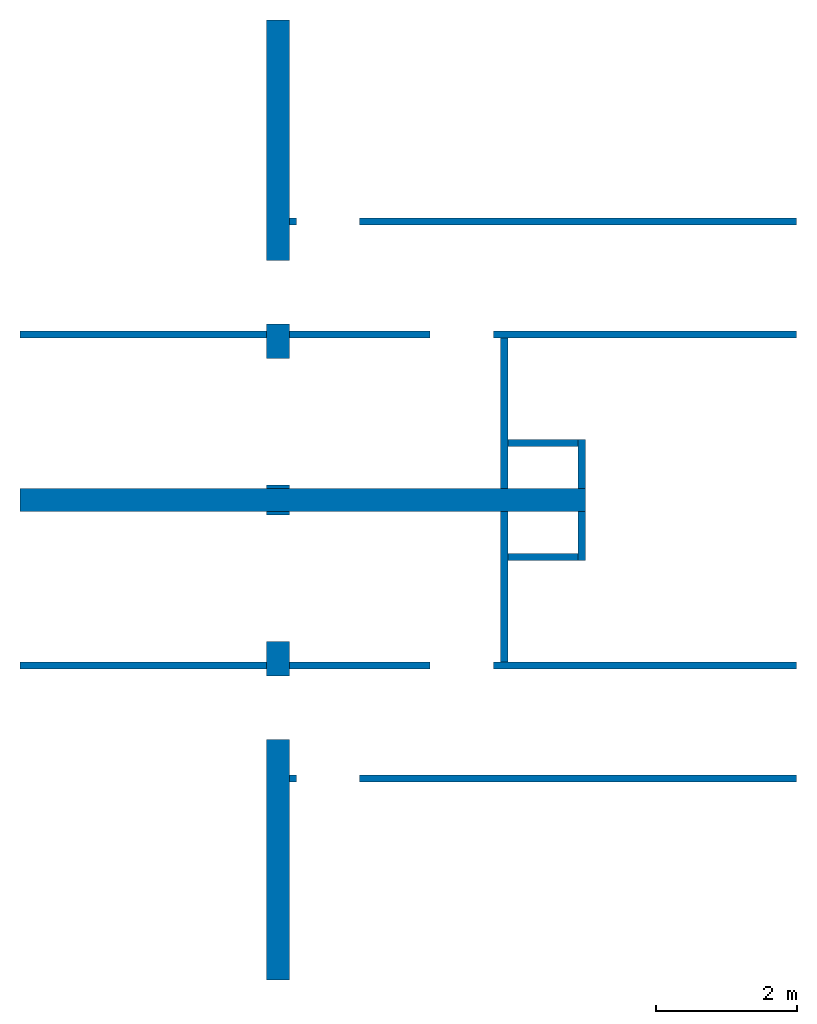
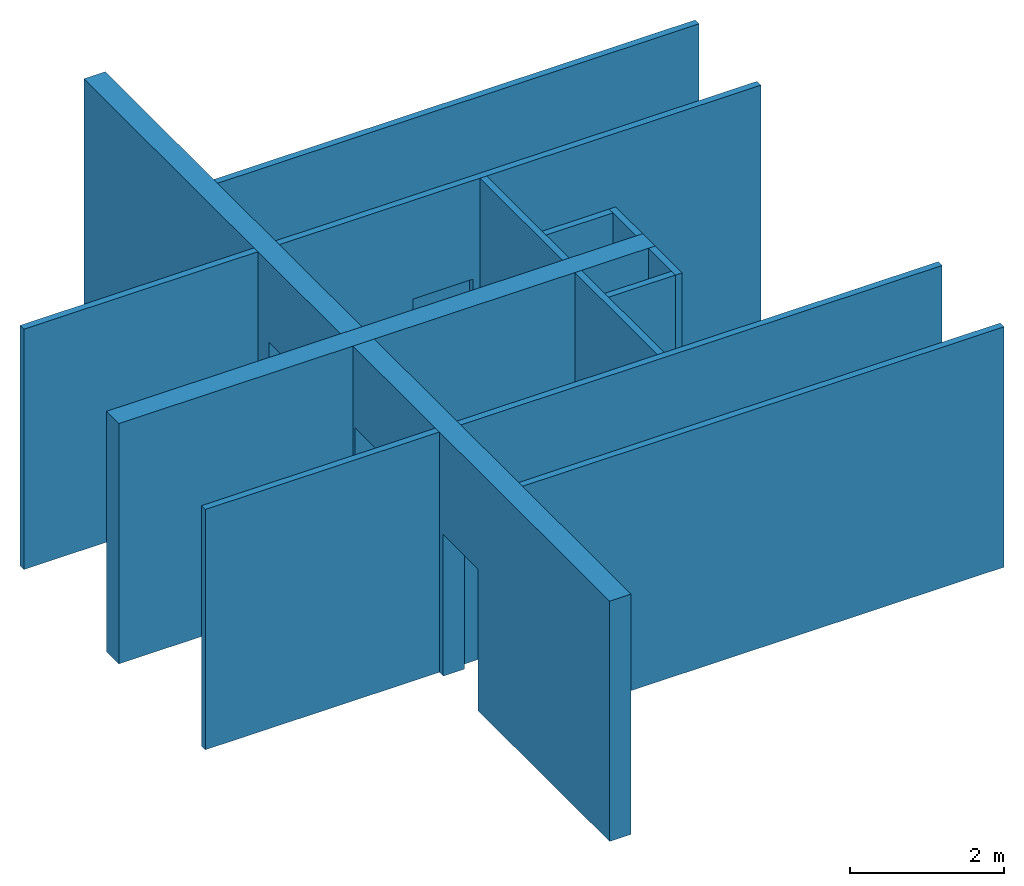
# One storey: 15 walls, 8 openings.
"""IFC2X3 building model written with IfcOpenShell, lengths in millimetres."""

from ifc_helpers import new_model, entity, si_unit, converted_unit, derived_unit, direction, frame, frame_2d, origin, origin_2d_with_axis, place, context, subcontext, project, spatial, rectangle, extrude, material, layer, layer_set, layer_usage, type_object, element, save


model = new_model("IFC2X3")

# Units and contexts
model_context = context("Model", 3, precision=0.01, world=origin(), true_north=direction((6.12303176911189e-17, 1.0)))
body_context = subcontext(model_context, "Body", "Model", "MODEL_VIEW")
ifc_project = project(units=[si_unit("LENGTHUNIT", "METRE", prefix="MILLI"), si_unit("AREAUNIT", "SQUARE_METRE"), si_unit("VOLUMEUNIT", "CUBIC_METRE"), converted_unit("PLANEANGLEUNIT", "DEGREE", entity("IfcRatioMeasure", 0.0174532925199433), si_unit("PLANEANGLEUNIT", "RADIAN"), dimensions=[0, 0, 0, 0, 0, 0, 0]), si_unit("MASSUNIT", "GRAM", prefix="KILO"), derived_unit("MASSDENSITYUNIT", [(si_unit("MASSUNIT", "GRAM", prefix="KILO"), 1), (si_unit("LENGTHUNIT", "METRE"), -3)]), si_unit("TIMEUNIT", "SECOND"), si_unit("FREQUENCYUNIT", "HERTZ"), si_unit("THERMODYNAMICTEMPERATUREUNIT", "DEGREE_CELSIUS"), derived_unit("THERMALTRANSMITTANCEUNIT", [(si_unit("MASSUNIT", "GRAM", prefix="KILO"), 1), (si_unit("THERMODYNAMICTEMPERATUREUNIT", "KELVIN"), -1), (si_unit("TIMEUNIT", "SECOND"), -3)]), derived_unit("VOLUMETRICFLOWRATEUNIT", [(si_unit("LENGTHUNIT", "METRE"), 3), (si_unit("TIMEUNIT", "SECOND"), -1)]), si_unit("ELECTRICCURRENTUNIT", "AMPERE"), si_unit("ELECTRICVOLTAGEUNIT", "VOLT"), si_unit("POWERUNIT", "WATT"), si_unit("FORCEUNIT", "NEWTON", prefix="KILO"), si_unit("ILLUMINANCEUNIT", "LUX"), si_unit("LUMINOUSFLUXUNIT", "LUMEN"), si_unit("LUMINOUSINTENSITYUNIT", "CANDELA"), derived_unit("USERDEFINED", [(si_unit("MASSUNIT", "GRAM", prefix="KILO"), -1), (si_unit("LENGTHUNIT", "METRE"), -2), (si_unit("TIMEUNIT", "SECOND"), 3), (si_unit("LUMINOUSFLUXUNIT", "LUMEN"), 1)]), derived_unit("LINEARVELOCITYUNIT", [(si_unit("LENGTHUNIT", "METRE"), 1), (si_unit("TIMEUNIT", "SECOND"), -1)]), si_unit("PRESSUREUNIT", "PASCAL"), derived_unit("USERDEFINED", [(si_unit("LENGTHUNIT", "METRE"), -2), (si_unit("MASSUNIT", "GRAM", prefix="KILO"), 1), (si_unit("TIMEUNIT", "SECOND"), -2)])], contexts=[model_context])

# Site, building, storey
site_placement = place(None, origin())
site = spatial("IfcSite", under=ifc_project, at=site_placement, CompositionType="ELEMENT")
building_placement = place(site_placement, origin())
building = spatial("IfcBuilding", under=site, at=building_placement, CompositionType="ELEMENT")
storey_placement = place(building_placement, origin())
storey = spatial("IfcBuildingStorey", under=building, at=storey_placement, Name="00 Ground level", CompositionType="ELEMENT", Elevation=0.0)

# Wall
ifc_material_1 = material(Name="03")
ifc_layer_1 = layer(ifc_material_1, 10.0)
ifc_material_2 = material()
ifc_layer_2 = layer(ifc_material_2, 300.0)
ifc_layer_3 = layer(ifc_material_1, 10.0)
ifc_layer_set_1 = layer_set([ifc_layer_1, ifc_layer_2, ifc_layer_3], Name="Basic Wall:01_fal 300 mm")
ifc_layer_usage_1 = layer_usage(ifc_layer_set_1, "AXIS2", "NEGATIVE", 160.0)
wall_type_1 = type_object("IfcWallType", Name="Basic Wall:01_fal 300 mm", PredefinedType="STANDARD", material=ifc_layer_set_1)
wall_1_placement = place(storey_placement, frame((17483.4900708518, -68831.2395851399, -140.0)))
element("IfcWallStandardCase", 1, at=wall_1_placement, inside=storey, type_object=wall_type_1, material=ifc_layer_usage_1, Name="Basic Wall:01_fal 300 mm", ObjectType="Basic Wall:01_fal 300 mm", context=body_context, shape_type="SweptSolid", body=[
    extrude(rectangle(XDim=8020.00000000003, YDim=319.999999999997, at=frame_2d((4010.00000000001, -5.96855898038484e-13), x_axis=(-1.0, 0.0))), origin(), (0.0, 0.0, 1.0), 3800.0),
])

# Wall, openings
ifc_layer_usage_2 = layer_usage(ifc_layer_set_1, "AXIS2", "NEGATIVE", 160.0)
wall_2_placement = place(storey_placement, frame((21143.4900708518, -75641.2395851399, -140.0), z_axis=(0.0, 0.0, 1.0), x_axis=(0.0, 1.0, 0.0)))
wall_2 = element("IfcWallStandardCase", 2, at=wall_2_placement, inside=storey, type_object=wall_type_1, material=ifc_layer_usage_2, Name="Basic Wall:01_fal 300 mm", ObjectType="Basic Wall:01_fal 300 mm", context=body_context, shape_type="SweptSolid", body=[
    extrude(rectangle(XDim=6650.0, YDim=319.999999999997, at=frame_2d((3325.0, 4.2632564145606e-14), x_axis=(-1.0, 0.0))), origin(), (0.0, 0.0, 1.0), 3800.0),
])
opening_1_placement = place(wall_2_placement, frame((4800.0, 160.0, 0.0)))
element("IfcOpeningElement", 3, at=opening_1_placement, cuts=wall_2, Name="Basic Wall:01_fal 300 mm", ObjectType="Opening", context=body_context, shape_type="SweptSolid", body=[
    extrude(rectangle(XDim=2540.0, YDim=1800.0, at=frame_2d((0.0, 4.32009983342141e-12), x_axis=(1.0, 0.0))), frame((900.0, -320.0, 1270.0), z_axis=(0.0, 1.0, 0.0), x_axis=(0.0, 0.0, -1.0)), (0.0, 0.0, 1.0), 319.999999999997),
])
opening_2_placement = place(wall_2_placement, frame((3410.0, 1364.0, 0.0), z_axis=(0.0, 0.0, 1.0), x_axis=(0.0, -1.0, 0.0)))
element("IfcOpeningElement", 4, at=opening_2_placement, cuts=wall_2, Name="Basic Wall:01_fal 300 mm", ObjectType="Opening", context=body_context, shape_type="SweptSolid", body=[
    extrude(rectangle(XDim=2240.0, YDim=900.000000000003, at=origin_2d_with_axis()), frame((3048.0, 450.0, 1120.0), z_axis=(-1.0, 0.0, 0.0), x_axis=(0.0, 0.0, 1.0)), (0.0, 0.0, 1.0), 3048.0),
])

ifc_layer_usage_3 = layer_usage(ifc_layer_set_1, "AXIS2", "POSITIVE", -160.0)
wall_3_placement = place(storey_placement, frame((21143.4900708518, -62021.2395851399, -140.0), z_axis=(0.0, 0.0, 1.0), x_axis=(0.0, -1.0, 0.0)))
wall_3 = element("IfcWallStandardCase", 5, at=wall_3_placement, inside=storey, type_object=wall_type_1, material=ifc_layer_usage_3, Name="Basic Wall:01_fal 300 mm", ObjectType="Basic Wall:01_fal 300 mm", context=body_context, shape_type="SweptSolid", body=[
    extrude(rectangle(XDim=6650.0, YDim=319.999999999997, at=frame_2d((3325.0, -5.82645043323282e-13), x_axis=(-1.0, 0.0))), origin(), (0.0, 0.0, 1.0), 3800.0),
])
opening_3_placement = place(wall_3_placement, frame((6600.0, -160.0, 0.0)))
element("IfcOpeningElement", 6, at=opening_3_placement, cuts=wall_3, Name="Basic Wall:01_fal 300 mm", ObjectType="Opening", context=body_context, shape_type="SweptSolid", body=[
    extrude(rectangle(XDim=2540.0, YDim=1800.0, at=frame_2d((0.0, 4.32009983342141e-12), x_axis=(1.0, 0.0))), frame((-900.0, 0.0, 1270.0), z_axis=(0.0, 1.0, 0.0), x_axis=(0.0, 0.0, -1.0)), (0.0, 0.0, 1.0), 319.999999999997),
])
opening_4_placement = place(wall_3_placement, frame((4310.0, -1364.0, 0.0), z_axis=(0.0, 0.0, 1.0), x_axis=(0.0, 1.0, 0.0)))
element("IfcOpeningElement", 7, at=opening_4_placement, cuts=wall_3, Name="Basic Wall:01_fal 300 mm", ObjectType="Opening", context=body_context, shape_type="SweptSolid", body=[
    extrude(rectangle(XDim=2240.0, YDim=900.000000000003, at=origin_2d_with_axis()), frame((0.0, 450.0, 1120.0), z_axis=(1.0, 0.0, 0.0), x_axis=(0.0, 0.0, 1.0)), (0.0, 0.0, 1.0), 3048.0),
])

# Walls
ifc_material_3 = material(Name="03")
ifc_layer_4 = layer(ifc_material_3, 12.5)
ifc_material_4 = material(Name="04_Akustik Board")
ifc_layer_5 = layer(ifc_material_4, 75.0)
ifc_layer_6 = layer(ifc_material_3, 12.5)
ifc_layer_set_2 = layer_set([ifc_layer_4, ifc_layer_5, ifc_layer_6], Name="Basic Wall:01_fal 100 mm - 1")
ifc_layer_usage_4 = layer_usage(ifc_layer_set_2, "AXIS2", "NEGATIVE", 50.0)
wall_type_2 = type_object("IfcWallType", Name="Basic Wall:01_fal 100 mm - 1", PredefinedType="STANDARD", material=ifc_layer_set_2)
wall_4_placement = place(storey_placement, frame((24353.4900708518, -71131.2395851399, -140.0), z_axis=(0.0, 0.0, 1.0), x_axis=(0.0, 1.0, 0.0)))
element("IfcWallStandardCase", 8, at=wall_4_placement, inside=storey, type_object=wall_type_2, material=ifc_layer_usage_4, Name="Basic Wall:01_fal 100 mm - 1", ObjectType="Basic Wall:01_fal 100 mm - 1", context=body_context, shape_type="SweptSolid", body=[
    extrude(rectangle(XDim=2140.00000000001, YDim=100.000000000003, at=frame_2d((1070.0, -8.5265128291212e-14), x_axis=(-1.0, 0.0))), origin(), (0.0, 0.0, 1.0), 3800.0),
])
ifc_layer_usage_5 = layer_usage(ifc_layer_set_2, "AXIS2", "NEGATIVE", 50.0)
wall_5_placement = place(storey_placement, frame((25453.4900708518, -69691.2395851399, -140.0), z_axis=(0.0, 0.0, 1.0), x_axis=(0.0, 1.0, 0.0)))
element("IfcWallStandardCase", 9, at=wall_5_placement, inside=storey, type_object=wall_type_2, material=ifc_layer_usage_5, Name="Basic Wall:01_fal 100 mm - 1", ObjectType="Basic Wall:01_fal 100 mm - 1", context=body_context, shape_type="SweptSolid", body=[
    extrude(rectangle(XDim=700.000000000005, YDim=100.000000000003, at=frame_2d((350.000000000003, 6.82121026329696e-13), x_axis=(-1.0, 0.0))), origin(), (0.0, 0.0, 1.0), 3800.0),
])
ifc_layer_usage_6 = layer_usage(ifc_layer_set_2, "AXIS2", "NEGATIVE", 50.0)
wall_6_placement = place(storey_placement, frame((24403.4900708518, -69641.2395851399, -140.0)))
element("IfcWallStandardCase", 10, at=wall_6_placement, inside=storey, type_object=wall_type_2, material=ifc_layer_usage_6, Name="Basic Wall:01_fal 100 mm - 1", ObjectType="Basic Wall:01_fal 100 mm - 1", context=body_context, shape_type="SweptSolid", body=[
    extrude(rectangle(XDim=1000.0, YDim=99.9999999999946, at=frame_2d((500.000000000001, 0.0), x_axis=(-1.0, 0.0))), origin(), (0.0, 0.0, 1.0), 3800.0),
])
ifc_layer_usage_7 = layer_usage(ifc_layer_set_2, "AXIS2", "POSITIVE", -50.0)
wall_7_placement = place(storey_placement, frame((24353.4900708518, -66531.2395851399, -140.0), z_axis=(0.0, 0.0, 1.0), x_axis=(0.0, -1.0, 0.0)))
element("IfcWallStandardCase", 11, at=wall_7_placement, inside=storey, type_object=wall_type_2, material=ifc_layer_usage_7, Name="Basic Wall:01_fal 100 mm - 1", ObjectType="Basic Wall:01_fal 100 mm - 1", context=body_context, shape_type="SweptSolid", body=[
    extrude(rectangle(XDim=2139.99999999998, YDim=100.000000000003, at=frame_2d((1069.99999999999, 6.03961325396085e-14), x_axis=(-1.0, 0.0))), origin(), (0.0, 0.0, 1.0), 3800.0),
])
ifc_layer_usage_8 = layer_usage(ifc_layer_set_2, "AXIS2", "POSITIVE", -50.0)
wall_8_placement = place(storey_placement, frame((25453.4900708518, -67971.2395851399, -140.0), z_axis=(0.0, 0.0, 1.0), x_axis=(0.0, -1.0, 0.0)))
element("IfcWallStandardCase", 12, at=wall_8_placement, inside=storey, type_object=wall_type_2, material=ifc_layer_usage_8, Name="Basic Wall:01_fal 100 mm - 1", ObjectType="Basic Wall:01_fal 100 mm - 1", context=body_context, shape_type="SweptSolid", body=[
    extrude(rectangle(XDim=699.999999999988, YDim=100.000000000003, at=frame_2d((349.999999999994, 1.4352963262354e-12), x_axis=(-1.0, 0.0))), origin(), (0.0, 0.0, 1.0), 3800.0),
])
ifc_layer_usage_9 = layer_usage(ifc_layer_set_2, "AXIS2", "POSITIVE", -50.0)
wall_9_placement = place(storey_placement, frame((24403.4900708518, -68021.2395851399, -140.0)))
element("IfcWallStandardCase", 13, at=wall_9_placement, inside=storey, type_object=wall_type_2, material=ifc_layer_usage_9, Name="Basic Wall:01_fal 100 mm - 1", ObjectType="Basic Wall:01_fal 100 mm - 1", context=body_context, shape_type="SweptSolid", body=[
    extrude(rectangle(XDim=1000.0, YDim=99.9999999999946, at=frame_2d((500.000000000001, -1.30384592011978e-12), x_axis=(-1.0, 0.0))), origin(), (0.0, 0.0, 1.0), 3800.0),
])
ifc_layer_usage_10 = layer_usage(ifc_layer_set_2, "AXIS2", "NEGATIVE", 50.0)
wall_10_placement = place(storey_placement, frame((17483.4900708518, -71181.2395851399, -140.0)))
element("IfcWallStandardCase", 14, at=wall_10_placement, inside=storey, type_object=wall_type_2, material=ifc_layer_usage_10, Name="Basic Wall:01_fal 100 mm - 1", ObjectType="Basic Wall:01_fal 100 mm - 1", context=body_context, shape_type="SweptSolid", body=[
    extrude(rectangle(XDim=3500.00000000002, YDim=99.9999999999946, at=frame_2d((1750.00000000001, 2.97362134915602e-12), x_axis=(-1.0, 0.0))), origin(), (0.0, 0.0, 1.0), 3800.0),
])

# Wall, opening
ifc_layer_usage_11 = layer_usage(ifc_layer_set_2, "AXIS2", "NEGATIVE", 50.0)
wall_11_placement = place(storey_placement, frame((21303.4900708518, -72781.2395851399, -140.0)))
wall_11 = element("IfcWallStandardCase", 15, at=wall_11_placement, inside=storey, type_object=wall_type_2, material=ifc_layer_usage_11, Name="Basic Wall:01_fal 100 mm - 1", ObjectType="Basic Wall:01_fal 100 mm - 1", context=body_context, shape_type="SweptSolid", body=[
    extrude(rectangle(XDim=7199.99999999999, YDim=99.9999999999946, at=frame_2d((3600.0, 2.03570493795269e-12), x_axis=(-1.0, 0.0))), origin(), (0.0, 0.0, 1.0), 3800.0),
])
opening_5_placement = place(wall_11_placement, frame((100.0, -1474.0, 0.0)))
element("IfcOpeningElement", 16, at=opening_5_placement, cuts=wall_11, Name="Basic Wall:01_fal 100 mm - 1", ObjectType="Opening", context=body_context, shape_type="SweptSolid", body=[
    extrude(rectangle(XDim=2240.0, YDim=900.000000000003, at=frame_2d((-2.1600499167107e-12, 0.0), x_axis=(0.0, 1.0))), frame((450.0, 0.0, 1120.0), z_axis=(0.0, 1.0, 0.0), x_axis=(-1.0, 0.0, 0.0)), (0.0, 0.0, 1.0), 3048.0),
])

ifc_layer_usage_12 = layer_usage(ifc_layer_set_2, "AXIS2", "NEGATIVE", 50.0)
wall_12_placement = place(storey_placement, frame((21303.4900708518, -71181.2395851399, -140.0)))
wall_12 = element("IfcWallStandardCase", 17, at=wall_12_placement, inside=storey, type_object=wall_type_2, material=ifc_layer_usage_12, Name="Basic Wall:01_fal 100 mm - 1", ObjectType="Basic Wall:01_fal 100 mm - 1", context=body_context, shape_type="SweptSolid", body=[
    extrude(rectangle(XDim=7199.99999999999, YDim=99.9999999999946, at=frame_2d((3600.0, 2.03570493795269e-12), x_axis=(-1.0, 0.0))), origin(), (0.0, 0.0, 1.0), 3800.0),
])
opening_6_placement = place(wall_12_placement, frame((2000.0, -1574.0, 0.0)))
element("IfcOpeningElement", 18, at=opening_6_placement, cuts=wall_12, Name="Basic Wall:01_fal 100 mm - 1", ObjectType="Opening", context=body_context, shape_type="SweptSolid", body=[
    extrude(rectangle(XDim=2240.0, YDim=899.999999999999, at=frame_2d((0.0, 4.32009983342141e-12), x_axis=(1.0, 0.0))), frame((450.0, 0.0, 1120.0), z_axis=(0.0, 1.0, 0.0), x_axis=(0.0, 0.0, 1.0)), (0.0, 0.0, 1.0), 3048.0),
])

# Wall
ifc_layer_usage_13 = layer_usage(ifc_layer_set_2, "AXIS2", "POSITIVE", -50.0)
wall_13_placement = place(storey_placement, frame((17483.4900708518, -66481.2395851399, -140.0)))
element("IfcWallStandardCase", 19, at=wall_13_placement, inside=storey, type_object=wall_type_2, material=ifc_layer_usage_13, Name="Basic Wall:01_fal 100 mm - 1", ObjectType="Basic Wall:01_fal 100 mm - 1", context=body_context, shape_type="SweptSolid", body=[
    extrude(rectangle(XDim=3500.00000000003, YDim=99.9999999999946, at=frame_2d((1750.00000000001, -5.32907051820075e-13), x_axis=(-1.0, 0.0))), origin(), (0.0, 0.0, 1.0), 3800.0),
])

# Wall, opening
ifc_layer_usage_14 = layer_usage(ifc_layer_set_2, "AXIS2", "POSITIVE", -50.0)
wall_14_placement = place(storey_placement, frame((21303.4900708518, -66481.2395851399, -140.0)))
wall_14 = element("IfcWallStandardCase", 20, at=wall_14_placement, inside=storey, type_object=wall_type_2, material=ifc_layer_usage_14, Name="Basic Wall:01_fal 100 mm - 1", ObjectType="Basic Wall:01_fal 100 mm - 1", context=body_context, shape_type="SweptSolid", body=[
    extrude(rectangle(XDim=7199.99999999999, YDim=99.9999999999946, at=frame_2d((3600.0, -8.45545855554519e-13), x_axis=(-1.0, 0.0))), origin(), (0.0, 0.0, 1.0), 3800.0),
])
opening_7_placement = place(wall_14_placement, frame((2000.0, -1474.0, 0.0)))
element("IfcOpeningElement", 21, at=opening_7_placement, cuts=wall_14, Name="Basic Wall:01_fal 100 mm - 1", ObjectType="Opening", context=body_context, shape_type="SweptSolid", body=[
    extrude(rectangle(XDim=2240.0, YDim=899.999999999999, at=frame_2d((0.0, 4.32009983342141e-12), x_axis=(1.0, 0.0))), frame((450.0, 0.0, 1120.0), z_axis=(0.0, 1.0, 0.0), x_axis=(0.0, 0.0, 1.0)), (0.0, 0.0, 1.0), 3048.0),
])

ifc_layer_usage_15 = layer_usage(ifc_layer_set_2, "AXIS2", "POSITIVE", -50.0)
wall_15_placement = place(storey_placement, frame((21303.4900708518, -64881.2395851399, -140.0)))
wall_15 = element("IfcWallStandardCase", 22, at=wall_15_placement, inside=storey, type_object=wall_type_2, material=ifc_layer_usage_15, Name="Basic Wall:01_fal 100 mm - 1", ObjectType="Basic Wall:01_fal 100 mm - 1", context=body_context, shape_type="SweptSolid", body=[
    extrude(rectangle(XDim=7199.99999999998, YDim=99.9999999999946, at=frame_2d((3599.99999999999, -8.45545855554519e-13), x_axis=(-1.0, 0.0))), origin(), (0.0, 0.0, 1.0), 3800.0),
])
opening_8_placement = place(wall_15_placement, frame((100.0, -1574.0, 0.0)))
element("IfcOpeningElement", 23, at=opening_8_placement, cuts=wall_15, Name="Basic Wall:01_fal 100 mm - 1", ObjectType="Opening", context=body_context, shape_type="SweptSolid", body=[
    extrude(rectangle(XDim=2240.0, YDim=900.000000000003, at=frame_2d((-2.1600499167107e-12, 0.0), x_axis=(0.0, 1.0))), frame((450.0, 0.0, 1120.0), z_axis=(0.0, 1.0, 0.0), x_axis=(-1.0, 0.0, 0.0)), (0.0, 0.0, 1.0), 3048.0),
])

save(model, "model.ifc")
